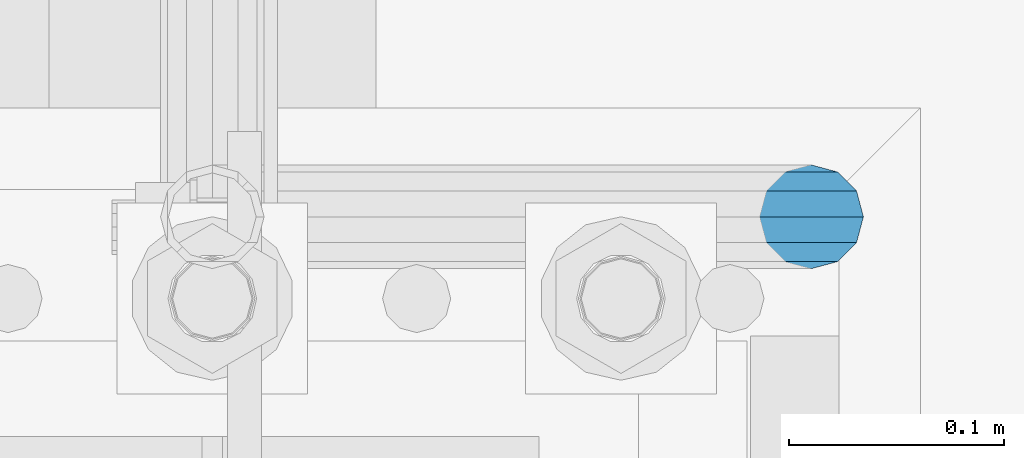
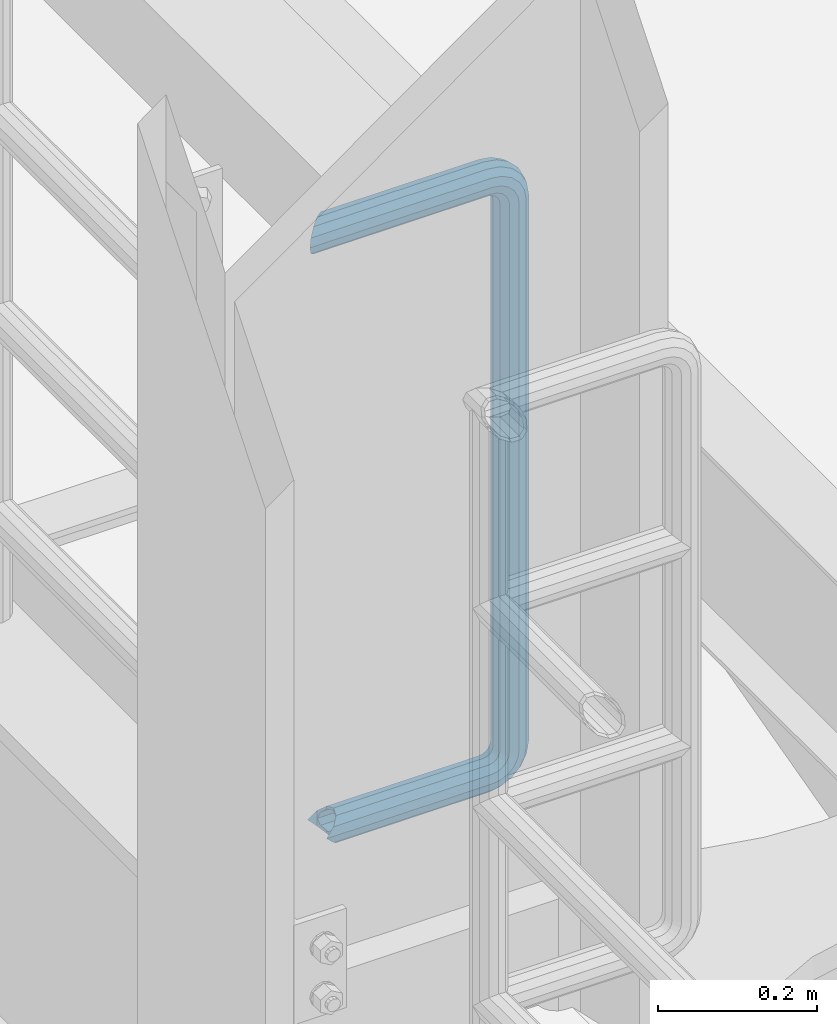
# One storey, part 959 of 1876: 1 beam, 1 element without a shape of its own.
"""IFC2X3 building model written with IfcOpenShell, lengths in millimetres."""

from ifc_helpers import new_model, si_unit, frame, origin_with_axes, place, context, subcontext, project, spatial, faceted_brep, material, type_object, element, aggregate, save


model = new_model("IFC2X3")

# Units and contexts
model_context = context("Model", 3, precision=1e-05, world=origin_with_axes())
body_context = subcontext(model_context, "Body", "Model", "MODEL_VIEW")
ifc_project = project(units=[si_unit("LENGTHUNIT", "METRE", prefix="MILLI"), si_unit("AREAUNIT", "SQUARE_METRE"), si_unit("VOLUMEUNIT", "CUBIC_METRE"), si_unit("MASSUNIT", "GRAM", prefix="KILO"), si_unit("TIMEUNIT", "SECOND"), si_unit("PLANEANGLEUNIT", "RADIAN"), si_unit("SOLIDANGLEUNIT", "STERADIAN"), si_unit("THERMODYNAMICTEMPERATUREUNIT", "DEGREE_CELSIUS"), si_unit("LUMINOUSINTENSITYUNIT", "LUMEN")], contexts=[model_context])

# Site, building, storey
site_placement = place(None, origin_with_axes())
site = spatial("IfcSite", under=ifc_project, at=site_placement, CompositionType="ELEMENT")
building_placement = place(site_placement, origin_with_axes())
building = spatial("IfcBuilding", under=site, at=building_placement, Name="Undefined", CompositionType="ELEMENT")
storey_placement = place(building_placement, origin_with_axes())
storey = spatial("IfcBuildingStorey", under=building, at=storey_placement, Name="Undefined", CompositionType="ELEMENT", Elevation=0.0)

# Assembly, beam
assembly_placement = place(storey_placement, origin_with_axes())
assembly = element("IfcElementAssembly", 1, at=assembly_placement, inside=storey, Name="RAIL", AssemblyPlace="NOTDEFINED", PredefinedType="RIGID_FRAME")
ifc_material = material()
beam_type = type_object("IfcBeamType", Name="PIPE1-1/2SCH40", PredefinedType="NOTDEFINED")
beam_placement = place(assembly_placement, frame((-5.00222085975111e-12, -4356.1, 6207.125), z_axis=(0.0, 0.0, 1.0), x_axis=(1.0, 0.0, 0.0)))
beam = element("IfcBeam", 2, at=beam_placement, type_object=beam_type, material=ifc_material, Name="RAIL", ObjectType="PIPE1-1/2SCH40", context=body_context, shape_type="Brep", body=[
    faceted_brep([(1.20714750983051e-12, 24.1299999999974, -914.399963378906), (12.0650000000014, 20.8971929933159, -926.464963378905), (12.0650000000014, 20.8971929933177, -902.334963378908), (12.0650000000014, -20.8971929933195, -902.334963378908), (12.0650000000014, -20.8971929933195, -926.464963378905), (1.52133659548828e-12, -24.130000000001, -914.399963378906), (20.8971929933199, -12.0650000000023, -893.502770385589), (20.8971929933199, -12.0650000000005, -898.533841947723), (15.2545715621378, -17.7076214311819, -904.176463378906), (12.5151929933181, -20.4470000000019, -914.399963378906), (15.2545715621376, -17.7076214311819, -924.623463378906), (20.8971929933199, -12.0650000000005, -930.26608481009), (20.8971929933199, -12.0650000000023, -935.297156372224), (24.1300000000014, -1.81898940354586e-12, -934.846963378906), (24.1300000000014, -1.81898940354586e-12, -938.529963378907), (21.3906214311813, -10.2235000000019, -932.107584810088), (21.3906214311823, 10.2234999999982, -932.107584810088), (20.8971929933199, 12.0650000000005, -930.266084810086), (20.8971929933199, 12.0649999999987, -935.297156372224), (15.2545715621413, 17.7076214311783, -924.623463378906), (12.5151929933216, 20.4469999999983, -914.399963378906), (15.2545715621411, 17.7076214311783, -904.176463378906), (20.8971929933199, 12.0650000000005, -898.533841947727), (20.8971929933199, 12.0649999999987, -893.502770385589), (21.3906214311822, 10.2234999999982, -896.692341947724), (24.1300000000014, 0.0, -893.952963378906), (24.1300000000014, 0.0, -890.269963378905), (21.3906214311814, -10.2235000000019, -896.692341947724), (241.299995422363, 20.8971929933177, -12.0649999999987), (241.299995422363, 24.1299999999992, 0.0), (253.073542436527, 24.1299999999992, -1.86474665447167), (249.345252399393, 20.8971929933177, -13.3392435235728), (241.299995422363, 12.0650000000005, -20.8971929933177), (246.615954666858, 12.0650000000005, -21.7391582230448), (241.299995422363, 0.0, -24.130000000001), (245.616962362259, 0.0, -24.8137403926739), (241.299995422363, -12.0650000000005, -20.8971929933177), (246.615954666858, -12.0650000000005, -21.7391582230448), (241.299995422363, -20.8971929933177, -12.0649999999987), (249.345252399393, -20.8971929933177, -13.3392435235728), (241.299995422363, -24.1299999999992, 0.0), (253.073542436527, -24.1299999999992, -1.86474665447167), (241.299995422363, -20.8971929933177, 12.0649999999987), (256.801832473661, -20.8971929933177, 9.60975021462946), (241.299995422363, -12.0650000000005, 20.8971929933177), (259.531130206197, -12.0650000000005, 18.0096649141014), (241.299995422363, 0.0, 24.130000000001), (260.530122510796, 0.0, 21.084247083727), (241.299995422363, 12.0650000000005, 20.8971929933177), (259.531130206197, 12.0650000000005, 18.0096649141014), (241.299995422363, 20.8971929933177, 12.0649999999987), (256.801832473661, 20.8971929933177, 9.60975021462946), (291.464993896486, -20.8971929933177, -38.0999984741211), (279.399993896484, -24.1299999999992, -38.0999984741211), (279.399993896484, -24.1299999999992, -876.299964904785), (291.464993896484, -20.8971929933177, -876.299964904785), (267.334993896485, -20.8971929933177, -38.0999984741211), (267.334993896484, -20.8971929933177, -876.299964904785), (258.502800903167, -12.0650000000005, -38.0999984741211), (258.502800903166, -12.0650000000005, -876.299964904785), (255.269993896485, 0.0, -38.0999984741211), (255.269993896484, 0.0, -876.299964904785), (258.502800903167, 12.0650000000005, -38.0999984741211), (258.502800903166, 12.0650000000005, -876.299964904785), (267.334993896485, 20.8971929933177, -38.0999984741211), (267.334993896484, 20.8971929933177, -876.299964904785), (279.399993896485, 24.1299999999992, -38.0999984741211), (279.399993896484, 24.1299999999992, -876.299964904785), (291.464993896486, 20.8971929933177, -38.0999984741211), (291.464993896484, 20.8971929933177, -876.299964904785), (300.297186889804, 12.0650000000005, -38.0999984741211), (300.297186889803, 12.0650000000005, -876.299964904785), (303.529993896486, 0.0, -38.0999984741211), (303.529993896484, 0.0, -876.299964904785), (300.297186889804, -12.0650000000005, -38.0999984741211), (300.297186889803, -12.0650000000005, -876.299964904785), (297.409658810584, -12.0650000000005, -894.531099688622), (300.484240980214, 0.0, -895.53009199322), (297.409658810584, 12.0650000000005, -894.531099688622), (289.009744111112, 20.8971929933177, -891.801801956084), (277.535247242011, 24.1299999999992, -888.073511918952), (266.06075037291, 20.8971929933177, -884.345221881817), (257.660835673438, 12.0650000000005, -881.615924149282), (254.586253503809, 0.0, -880.616931844681), (257.660835673438, -12.0650000000005, -881.615924149282), (266.06075037291, -20.8971929933177, -884.345221881817), (277.535247242011, -24.130000000001, -888.073511918952), (289.009744111112, -20.8971929933195, -891.801801956084), (241.299995422363, -20.8971929933195, -902.334963378908), (241.299995422363, -12.0650000000005, -893.502770385589), (241.299995422363, -24.130000000001, -914.399963378906), (241.299995422364, -20.8971929933195, -926.464963378909), (241.299995422364, -12.0650000000005, -935.297156372228), (241.299995422364, -1.81898940354586e-12, -938.529963378911), (241.299995422364, 12.0649999999987, -935.297156372228), (241.299995422364, 20.8971929933177, -926.464963378909), (241.299995422364, 24.1299999999992, -914.39996337891), (241.299995422363, 20.8971929933177, -902.334963378908), (241.299995422363, 12.0649999999987, -893.502770385589), (241.299995422363, 0.0, -890.269963378909), (245.61696236226, 0.0, -889.586222986232), (246.615954666859, -12.0650000000005, -892.660805155861), (246.615954666859, 12.0649999999987, -892.660805155861), (249.345252399395, 20.8971929933177, -901.060719855333), (253.07354243653, 24.1299999999992, -912.535216724435), (256.801832473666, 20.8971929933177, -924.009713593536), (259.531130206202, 12.0649999999987, -932.409628293008), (260.530122510801, 0.0, -935.484210462637), (259.531130206201, -12.0650000000005, -932.409628293008), (256.801832473666, -20.8971929933195, -924.009713593536), (253.07354243653, -24.130000000001, -912.535216724435), (249.345252399395, -20.8971929933195, -901.060719855333), (251.411550782037, -12.0650000000005, -890.21732688968), (256.602983568912, -20.8971929933195, -897.362721118872), (249.511354500001, 0.0, -887.601931081743), (251.411550782037, 12.0650000000005, -890.21732688968), (256.602983568912, 20.8971929933177, -897.362721118872), (263.694612637823, 24.1299999999992, -907.123511156005), (270.786241706733, 20.8971929933177, -916.884301193139), (275.977674493594, 12.0649999999987, -924.029695422345), (277.877870775644, 0.0, -926.645091230272), (275.977674493608, -12.0650000000005, -924.029695422334), (270.786241706733, -20.8971929933195, -916.884301193139), (263.694612637823, -24.130000000001, -907.123511156005), (262.362751636451, -20.8971929933195, -891.602953051333), (272.123541673585, -24.130000000001, -898.694582120243), (255.217357407258, -12.0650000000005, -886.411520264461), (252.601961599318, 0.0, -884.511323982424), (255.217357407258, 12.0650000000005, -886.411520264461), (262.362751636451, 20.8971929933177, -891.602953051333), (272.123541673585, 24.1299999999992, -898.694582120243), (281.884331710718, 20.8971929933177, -905.786211189152), (289.029725939912, 12.0650000000005, -910.977643976028), (291.645121747852, 0.0, -912.877840258065), (289.029725939912, -12.0650000000005, -910.977643976028), (281.884331710718, -20.8971929933195, -905.786211189152), (289.009744111112, -20.8971929933177, -22.5981614228222), (297.409658810584, -12.0650000000005, -19.8688636902843), (277.535247242011, -24.1299999999992, -26.3264514599541), (266.060750372911, -20.8971929933177, -30.0547414970897), (257.660835673439, -12.0650000000005, -32.7840392296275), (254.58625350381, 0.0, -33.7830315342253), (257.660835673439, 12.0650000000005, -32.7840392296275), (266.060750372911, 20.8971929933177, -30.0547414970897), (277.535247242011, 24.1299999999992, -26.3264514599541), (289.009744111112, 20.8971929933177, -22.5981614228222), (297.409658810584, 12.0650000000005, -19.8688636902843), (300.484240980213, 0.0, -18.8698713856866), (289.029725939909, -12.0650000000005, -3.42231940287456), (291.645121747848, 0.0, -1.52212312084157), (281.884331710716, -20.8971929933177, -8.61375218975081), (272.123541673583, -24.1299999999992, -15.7053812586601), (262.362751636451, -20.8971929933177, -22.7970103275729), (255.217357407257, -12.0650000000005, -27.9884431144455), (252.601961599318, 0.0, -29.8886393964822), (255.217357407257, 12.0650000000005, -27.9884431144455), (262.362751636451, 20.8971929933177, -22.7970103275729), (272.123541673583, 24.1299999999992, -15.7053812586601), (281.884331710716, 20.8971929933177, -8.61375218975081), (289.029725939909, 12.0650000000005, -3.42231940287456), (277.877870775642, 0.0, 12.2451278513654), (275.977674493607, 12.0650000000005, 9.62973204342416), (275.977674493607, -12.0650000000005, 9.62973204342416), (270.786241706732, -20.8971929933177, 2.48433781423228), (263.694612637822, -24.1299999999992, -7.27645222290084), (256.602983568912, -20.8971929933177, -17.037242260034), (251.411550782037, -12.0650000000005, -24.1826364892258), (249.511354500002, 0.0, -26.7980322971671), (251.411550782037, 12.0650000000005, -24.1826364892258), (256.602983568912, 20.8971929933177, -17.037242260034), (263.694612637822, 24.1299999999992, -7.27645222290084), (270.786241706732, 20.8971929933177, 2.48433781423228), (24.1300000000047, 24.1299999999992, 0.0), (20.8971929933232, 20.8971929933177, 12.0649999999987), (12.0650000000041, 12.0650000000005, 20.8971929933177), (-1.45519152283669e-11, 0.0, 24.130000000001), (-12.0649999999951, -12.0650000000005, 20.8971929933177), (-20.8971929933141, -20.8971929933177, 12.0649999999987), (0.0, -24.1299999999992, 0.0), (-24.1299999999956, -24.1299999999992, 0.0), (-12.0650000000096, -20.8971929933177, -12.0649999999987), (12.0650000000064, -20.8971929933177, -12.0649999999987), (-20.8971929933141, -20.8971929933177, -12.0649999999987), (-12.0649999999951, -12.0650000000005, -20.8971929933177), (20.8971929933249, -12.0650000000005, -20.8971929933177), (-16.481093238739, -16.4810932387427, -16.4810997545756), (24.1300000000063, 0.0, -24.130000000001), (-1.45519152283669e-11, 0.0, -24.130000000001), (20.8971929933249, 12.0650000000005, -20.8971929933177), (12.0650000000041, 12.0650000000005, -20.8971929933177), (20.8971929933232, 20.8971929933177, -12.0649999999987), (16.481099754581, 16.4810997545774, -16.4810932387409), (241.299995422363, -17.7076214311801, 10.2235000000001), (241.299995422363, -20.4470000000001, 0.0), (-20.4469999999956, -20.4470000000001, 0.0), (-17.7076214311755, -17.7076214311801, 10.2235000000001), (241.299995422363, -17.7076214311801, -10.2235000000001), (-17.7076214311755, -17.7076214311801, -10.2235000000001), (241.299995422363, -10.2235000000001, -17.7076214311819), (-10.2234999999955, -10.2235000000001, -17.7076214311819), (241.299995422363, 0.0, -20.4470000000001), (-1.45519152283669e-11, 0.0, -20.4470000000001), (241.299995422363, 10.2235000000001, -17.7076214311819), (10.2235000000046, 10.2235000000001, -17.7076214311819), (241.299995422363, 17.7076214311801, -10.2235000000001), (17.7076214311846, 17.7076214311801, -10.2235000000001), (241.299995422363, 20.4470000000001, 0.0), (20.4470000000047, 20.4470000000001, 0.0), (241.299995422363, 0.0, 20.4470000000001), (241.299995422363, -10.2235000000001, 17.7076214311819), (-10.2234999999955, -10.2235000000001, 17.7076214311819), (-1.45519152283669e-11, 0.0, 20.4470000000001), (241.299995422363, 10.2235000000001, 17.7076214311819), (10.2235000000046, 10.2235000000001, 17.7076214311819), (241.299995422363, 17.7076214311801, 10.2235000000001), (17.7076214311846, 17.7076214311801, 10.2235000000001), (258.545498388721, -10.2235000000001, 14.9762020957387), (256.23277767852, -17.7076214311801, 7.85837963987069), (253.073542436527, -20.4470000000001, -1.86474665447167), (249.914307194535, -17.7076214311801, -11.5878729488177), (247.601586484334, -10.2235000000001, -18.7056954046857), (246.755071952542, 0.0, -21.31099924316), (247.601586484334, 10.2235000000001, -18.7056954046857), (249.914307194535, 17.7076214311801, -11.5878729488177), (253.073542436527, 20.4470000000001, -1.86474665447167), (256.23277767852, 17.7076214311801, 7.85837963987069), (258.545498388721, 10.2235000000001, 14.9762020957387), (259.392012920513, 0.0, 17.5815059342131), (275.713057691449, 0.0, 9.26551826108334), (274.10289136825, -10.2235000000001, 7.04931444488102), (274.10289136825, 10.2235000000001, 7.04931444488102), (269.703835164635, 17.7076214311801, 0.994533019089431), (263.694612637822, 20.4470000000001, -7.27645222290084), (257.685390111009, 17.7076214311801, -15.5474374648911), (253.286333907394, 10.2235000000001, -21.6022188906827), (251.676167584195, 0.0, -23.818422706885), (253.286333907394, -10.2235000000001, -21.6022188906827), (257.685390111009, -17.7076214311801, -15.5474374648911), (263.694612637822, -20.4470000000001, -7.27645222290084), (269.703835164635, -17.7076214311801, 0.994533019089431), (286.449308341364, -10.2235000000001, -5.29710252823133), (280.394526915574, -17.7076214311801, -9.69615873184739), (288.665512157566, 0.0, -3.68693620503473), (286.449308341364, 10.2235000000001, -5.29710252823133), (280.394526915574, 17.7076214311801, -9.69615873184739), (272.123541673583, 20.4470000000001, -15.7053812586601), (263.852556431592, 17.7076214311801, -21.7146037854764), (257.797775005802, 10.2235000000001, -26.1136599890888), (255.581571189601, 0.0, -27.723826312289), (257.797775005802, -10.2235000000001, -26.1136599890888), (263.852556431592, -17.7076214311801, -21.7146037854764), (272.123541673583, -20.4470000000001, -15.7053812586601), (287.258373536355, -17.7076214311801, -23.1672162179639), (277.535247242011, -20.4470000000001, -26.3264514599541), (294.376195992223, -10.2235000000001, -20.8544955077632), (296.981499830698, 0.0, -20.00798097597), (294.376195992223, 10.2235000000001, -20.8544955077632), (287.258373536355, 17.7076214311801, -23.1672162179639), (277.535247242011, 20.4470000000001, -26.3264514599541), (267.812120947668, 17.7076214311801, -29.485686701948), (260.6942984918, 10.2235000000001, -31.7984074121487), (258.088994653325, 0.0, -32.6449219439419), (260.6942984918, -10.2235000000001, -31.7984074121487), (267.812120947668, -17.7076214311801, -29.485686701948), (279.399993896484, -20.4470000000001, -38.0999984741211), (269.176493896485, -17.7076214311801, -38.0999984741211), (289.623493896486, -17.7076214311801, -38.0999984741211), (297.107615327666, -10.2235000000001, -38.0999984741211), (299.846993896486, 0.0, -38.0999984741211), (297.107615327666, 10.2235000000001, -38.0999984741211), (289.623493896486, 17.7076214311801, -38.0999984741211), (279.399993896485, 20.4470000000001, -38.0999984741211), (269.176493896485, 17.7076214311801, -38.0999984741211), (261.692372465305, 10.2235000000001, -38.0999984741211), (258.952993896485, 0.0, -38.0999984741211), (261.692372465305, -10.2235000000001, -38.0999984741211), (269.176493896484, -17.7076214311801, -876.299964904785), (261.692372465304, -10.2235000000001, -876.299964904785), (258.952993896484, 0.0, -876.299964904785), (261.692372465304, 10.2235000000001, -876.299964904785), (269.176493896484, 17.7076214311801, -876.299964904785), (279.399993896484, 20.4470000000001, -876.299964904785), (289.623493896484, 17.7076214311801, -876.299964904785), (297.107615327665, 10.2235000000001, -876.299964904785), (299.846993896484, 0.0, -876.299964904785), (297.107615327665, -10.2235000000001, -876.299964904785), (289.623493896484, -17.7076214311801, -876.299964904785), (279.399993896484, -20.4470000000001, -876.299964904785), (277.535247242011, -20.4470000000001, -888.073511918952), (267.812120947667, -17.7076214311801, -884.914276676958), (260.694298491799, -10.2235000000001, -882.601555966758), (258.088994653324, 0.0, -881.755041434964), (260.694298491799, 10.2235000000001, -882.601555966758), (267.812120947668, 17.7076214311801, -884.914276676958), (277.535247242011, 20.4470000000001, -888.073511918952), (287.258373536355, 17.7076214311801, -891.232747160942), (294.376195992223, 10.2235000000001, -893.545467871143), (296.981499830699, 0.0, -894.391982402936), (294.376195992223, -10.2235000000001, -893.545467871143), (287.258373536355, -17.7076214311801, -891.232747160942), (280.394526915577, -17.7076214311801, -904.703804647055), (272.123541673585, -20.4470000000001, -898.694582120243), (286.449308341367, -10.2235000000001, -909.102860850671), (288.665512157569, 0.0, -910.713027173868), (286.449308341367, 10.2235000000001, -909.102860850671), (280.394526915577, 17.7076214311801, -904.703804647055), (272.123541673585, 20.4470000000001, -898.694582120243), (263.852556431593, 17.7076214311801, -892.68535959343), (257.797775005802, 10.2235000000001, -888.286303389817), (255.581571189601, 0.0, -886.676137066617), (257.797775005802, -10.2235000000001, -888.286303389817), (263.852556431593, -17.7076214311801, -892.68535959343), (263.694612637823, -20.4470000000001, -907.123511156005), (257.685390111009, -17.7076214311801, -898.852525914015), (269.703835164636, -17.7076214311801, -915.394496397999), (274.102891368238, -10.2235000000001, -921.449277823798), (275.71305769145, 0.0, -923.66548163999), (274.102891368251, 10.2235000000001, -921.449277823787), (269.703835164636, 17.7076214311801, -915.394496397999), (263.694612637823, 20.4470000000001, -907.123511156005), (257.685390111009, 17.7076214311801, -898.852525914015), (253.286333907394, 10.2235000000001, -892.797744488227), (251.676167584195, 0.0, -890.581540672025), (253.286333907394, -10.2235000000001, -892.797744488227), (249.914307194537, -17.7076214311801, -902.812090430092), (247.601586484335, -10.2235000000001, -895.694267974224), (253.07354243653, -20.4470000000001, -912.535216724435), (256.232777678524, -17.7076214311819, -922.258343018777), (258.545498388725, -10.2235000000001, -929.376165474645), (259.392012920517, 0.0, -931.981469313119), (258.545498388725, 10.2235000000001, -929.376165474645), (256.232777678524, 17.7076214311801, -922.258343018777), (253.07354243653, 20.4470000000001, -912.535216724435), (249.914307194537, 17.7076214311801, -902.812090430092), (247.601586484335, 10.2235000000001, -895.694267974224), (246.755071952543, 0.0, -893.088964135746), (241.299995422363, -10.2235000000001, -896.692341947728), (241.299995422363, 0.0, -893.95296337891), (241.299995422363, -17.7076214311819, -904.17646337891), (241.299995422363, -20.4470000000001, -914.399963378906), (241.299995422364, -17.7076214311819, -924.62346337891), (241.299995422364, -10.2235000000001, -932.107584810088), (241.299995422364, -1.81898940354586e-12, -934.84696337891), (241.299995422364, 10.2234999999982, -932.107584810088), (241.299995422364, 17.7076214311801, -924.62346337891), (241.299995422364, 20.4470000000001, -914.39996337891), (241.299995422363, 17.7076214311801, -904.17646337891), (241.299995422363, 10.2235000000001, -896.692341947728)], [[[0, 1, 2]], [[3, 4, 5]], [[6, 7, 8, 9, 10, 11, 12, 4, 3]], [[13, 14, 12, 11, 15]], [[16, 17, 18, 14, 13]], [[2, 1, 18, 17, 19, 20, 21, 22, 23]], [[23, 22, 24, 25, 26]], [[26, 25, 27, 7, 6]], [[28, 29, 30, 31]], [[32, 28, 31, 33]], [[34, 32, 33, 35]], [[36, 34, 35, 37]], [[38, 36, 37, 39]], [[40, 38, 39, 41]], [[42, 40, 41, 43]], [[44, 42, 43, 45]], [[46, 44, 45, 47]], [[48, 46, 47, 49]], [[50, 48, 49, 51]], [[52, 53, 54, 55]], [[53, 56, 57, 54]], [[56, 58, 59, 57]], [[58, 60, 61, 59]], [[60, 62, 63, 61]], [[62, 64, 65, 63]], [[64, 66, 67, 65]], [[66, 68, 69, 67]], [[68, 70, 71, 69]], [[70, 72, 73, 71]], [[72, 74, 75, 73]], [[73, 75, 76, 77]], [[71, 73, 77, 78]], [[69, 71, 78, 79]], [[67, 69, 79, 80]], [[65, 67, 80, 81]], [[63, 65, 81, 82]], [[61, 63, 82, 83]], [[59, 61, 83, 84]], [[57, 59, 84, 85]], [[54, 57, 85, 86]], [[55, 54, 86, 87]], [[88, 89, 6, 3]], [[90, 88, 3, 5]], [[91, 90, 5, 4]], [[92, 91, 4, 12]], [[93, 92, 12, 14]], [[94, 93, 14, 18]], [[95, 94, 18, 1]], [[96, 95, 1, 0]], [[97, 96, 0, 2]], [[98, 97, 2, 23]], [[99, 98, 23, 26]], [[89, 99, 26, 6]], [[100, 99, 89, 101]], [[102, 98, 99, 100]], [[103, 97, 98, 102]], [[104, 96, 97, 103]], [[105, 95, 96, 104]], [[106, 94, 95, 105]], [[107, 93, 94, 106]], [[108, 92, 93, 107]], [[109, 91, 92, 108]], [[110, 90, 91, 109]], [[111, 88, 90, 110]], [[101, 89, 88, 111]], [[112, 101, 111, 113]], [[114, 100, 101, 112]], [[115, 102, 100, 114]], [[116, 103, 102, 115]], [[117, 104, 103, 116]], [[118, 105, 104, 117]], [[119, 106, 105, 118]], [[120, 107, 106, 119]], [[121, 108, 107, 120]], [[122, 109, 108, 121]], [[123, 110, 109, 122]], [[113, 111, 110, 123]], [[124, 113, 123, 125]], [[126, 112, 113, 124]], [[127, 114, 112, 126]], [[128, 115, 114, 127]], [[129, 116, 115, 128]], [[130, 117, 116, 129]], [[131, 118, 117, 130]], [[132, 119, 118, 131]], [[133, 120, 119, 132]], [[134, 121, 120, 133]], [[135, 122, 121, 134]], [[125, 123, 122, 135]], [[86, 125, 135, 87]], [[85, 124, 125, 86]], [[84, 126, 124, 85]], [[83, 127, 126, 84]], [[82, 128, 127, 83]], [[81, 129, 128, 82]], [[80, 130, 129, 81]], [[79, 131, 130, 80]], [[78, 132, 131, 79]], [[77, 133, 132, 78]], [[76, 134, 133, 77]], [[87, 135, 134, 76]], [[75, 55, 87, 76]], [[74, 52, 55, 75]], [[136, 52, 74, 137]], [[138, 53, 52, 136]], [[139, 56, 53, 138]], [[140, 58, 56, 139]], [[141, 60, 58, 140]], [[142, 62, 60, 141]], [[143, 64, 62, 142]], [[144, 66, 64, 143]], [[145, 68, 66, 144]], [[146, 70, 68, 145]], [[147, 72, 70, 146]], [[137, 74, 72, 147]], [[148, 137, 147, 149]], [[150, 136, 137, 148]], [[151, 138, 136, 150]], [[152, 139, 138, 151]], [[153, 140, 139, 152]], [[154, 141, 140, 153]], [[155, 142, 141, 154]], [[156, 143, 142, 155]], [[157, 144, 143, 156]], [[158, 145, 144, 157]], [[159, 146, 145, 158]], [[149, 147, 146, 159]], [[160, 149, 159, 161]], [[162, 148, 149, 160]], [[163, 150, 148, 162]], [[164, 151, 150, 163]], [[165, 152, 151, 164]], [[166, 153, 152, 165]], [[167, 154, 153, 166]], [[168, 155, 154, 167]], [[169, 156, 155, 168]], [[170, 157, 156, 169]], [[171, 158, 157, 170]], [[161, 159, 158, 171]], [[49, 161, 171, 51]], [[47, 160, 161, 49]], [[45, 162, 160, 47]], [[43, 163, 162, 45]], [[41, 164, 163, 43]], [[39, 165, 164, 41]], [[37, 166, 165, 39]], [[35, 167, 166, 37]], [[33, 168, 167, 35]], [[31, 169, 168, 33]], [[30, 170, 169, 31]], [[51, 171, 170, 30]], [[29, 50, 51, 30]], [[50, 29, 172, 173]], [[48, 50, 173, 174]], [[46, 48, 174, 175]], [[44, 46, 175, 176]], [[42, 44, 176, 177]], [[178, 40, 42, 177, 179]], [[180, 181, 38, 40, 178, 179, 182]], [[183, 184, 36, 38, 181, 180, 182, 185]], [[186, 34, 36, 184, 183, 187]], [[188, 32, 34, 186, 187, 189]], [[190, 28, 32, 188, 189, 191]], [[29, 28, 190, 172]], [[192, 193, 194, 195]], [[193, 196, 197, 194]], [[196, 198, 199, 197]], [[198, 200, 201, 199]], [[200, 202, 203, 201]], [[202, 204, 205, 203]], [[204, 206, 207, 205]], [[208, 209, 210, 211]], [[212, 208, 211, 213]], [[214, 212, 213, 215]], [[206, 214, 215, 207]], [[191, 189, 187, 183, 185, 182, 179, 177, 176, 175, 174, 173, 172, 190], [213, 211, 210, 195, 194, 197, 199, 201, 203, 205, 207, 215]], [[209, 192, 195, 210]], [[192, 209, 216, 217]], [[193, 192, 217, 218]], [[196, 193, 218, 219]], [[198, 196, 219, 220]], [[200, 198, 220, 221]], [[202, 200, 221, 222]], [[204, 202, 222, 223]], [[206, 204, 223, 224]], [[214, 206, 224, 225]], [[212, 214, 225, 226]], [[208, 212, 226, 227]], [[209, 208, 227, 216]], [[227, 228, 229, 216]], [[226, 230, 228, 227]], [[225, 231, 230, 226]], [[224, 232, 231, 225]], [[223, 233, 232, 224]], [[222, 234, 233, 223]], [[221, 235, 234, 222]], [[220, 236, 235, 221]], [[219, 237, 236, 220]], [[218, 238, 237, 219]], [[217, 239, 238, 218]], [[216, 229, 239, 217]], [[229, 240, 241, 239]], [[228, 242, 240, 229]], [[230, 243, 242, 228]], [[231, 244, 243, 230]], [[232, 245, 244, 231]], [[233, 246, 245, 232]], [[234, 247, 246, 233]], [[235, 248, 247, 234]], [[236, 249, 248, 235]], [[237, 250, 249, 236]], [[238, 251, 250, 237]], [[239, 241, 251, 238]], [[241, 252, 253, 251]], [[240, 254, 252, 241]], [[242, 255, 254, 240]], [[243, 256, 255, 242]], [[244, 257, 256, 243]], [[245, 258, 257, 244]], [[246, 259, 258, 245]], [[247, 260, 259, 246]], [[248, 261, 260, 247]], [[249, 262, 261, 248]], [[250, 263, 262, 249]], [[251, 253, 263, 250]], [[253, 264, 265, 263]], [[252, 266, 264, 253]], [[254, 267, 266, 252]], [[255, 268, 267, 254]], [[256, 269, 268, 255]], [[257, 270, 269, 256]], [[258, 271, 270, 257]], [[259, 272, 271, 258]], [[260, 273, 272, 259]], [[261, 274, 273, 260]], [[262, 275, 274, 261]], [[263, 265, 275, 262]], [[275, 265, 276, 277]], [[274, 275, 277, 278]], [[273, 274, 278, 279]], [[272, 273, 279, 280]], [[271, 272, 280, 281]], [[270, 271, 281, 282]], [[269, 270, 282, 283]], [[268, 269, 283, 284]], [[267, 268, 284, 285]], [[266, 267, 285, 286]], [[264, 266, 286, 287]], [[265, 264, 287, 276]], [[276, 287, 288, 289]], [[277, 276, 289, 290]], [[278, 277, 290, 291]], [[279, 278, 291, 292]], [[280, 279, 292, 293]], [[281, 280, 293, 294]], [[282, 281, 294, 295]], [[283, 282, 295, 296]], [[284, 283, 296, 297]], [[285, 284, 297, 298]], [[286, 285, 298, 299]], [[287, 286, 299, 288]], [[299, 300, 301, 288]], [[298, 302, 300, 299]], [[297, 303, 302, 298]], [[296, 304, 303, 297]], [[295, 305, 304, 296]], [[294, 306, 305, 295]], [[293, 307, 306, 294]], [[292, 308, 307, 293]], [[291, 309, 308, 292]], [[290, 310, 309, 291]], [[289, 311, 310, 290]], [[288, 301, 311, 289]], [[301, 312, 313, 311]], [[300, 314, 312, 301]], [[302, 315, 314, 300]], [[303, 316, 315, 302]], [[304, 317, 316, 303]], [[305, 318, 317, 304]], [[306, 319, 318, 305]], [[307, 320, 319, 306]], [[308, 321, 320, 307]], [[309, 322, 321, 308]], [[310, 323, 322, 309]], [[311, 313, 323, 310]], [[313, 324, 325, 323]], [[312, 326, 324, 313]], [[314, 327, 326, 312]], [[315, 328, 327, 314]], [[316, 329, 328, 315]], [[317, 330, 329, 316]], [[318, 331, 330, 317]], [[319, 332, 331, 318]], [[320, 333, 332, 319]], [[321, 334, 333, 320]], [[322, 335, 334, 321]], [[323, 325, 335, 322]], [[325, 336, 337, 335]], [[324, 338, 336, 325]], [[326, 339, 338, 324]], [[327, 340, 339, 326]], [[328, 341, 340, 327]], [[329, 342, 341, 328]], [[330, 343, 342, 329]], [[331, 344, 343, 330]], [[332, 345, 344, 331]], [[333, 346, 345, 332]], [[334, 347, 346, 333]], [[335, 337, 347, 334]], [[347, 337, 25, 24]], [[21, 346, 347, 24, 22]], [[345, 346, 21, 20]], [[344, 345, 20, 19]], [[343, 344, 19, 17, 16]], [[342, 343, 16, 13]], [[341, 342, 13, 15]], [[10, 340, 341, 15, 11]], [[339, 340, 10, 9]], [[338, 339, 9, 8]], [[336, 338, 8, 7, 27]], [[337, 336, 27, 25]]]),
])
aggregate(assembly, [beam])

save(model, "model.ifc")
